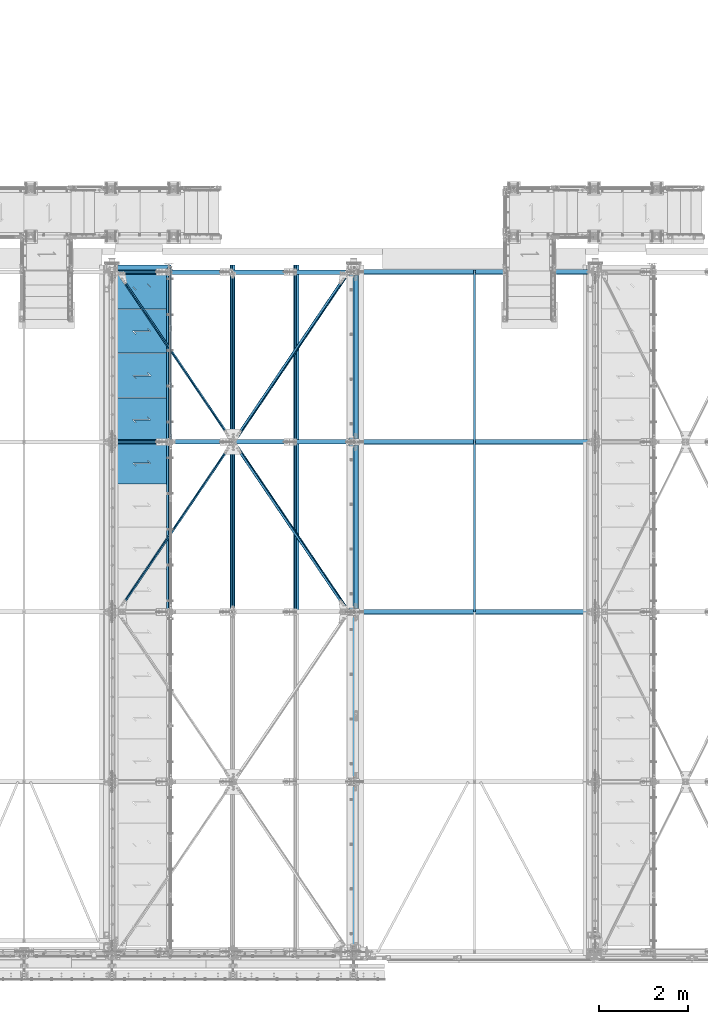
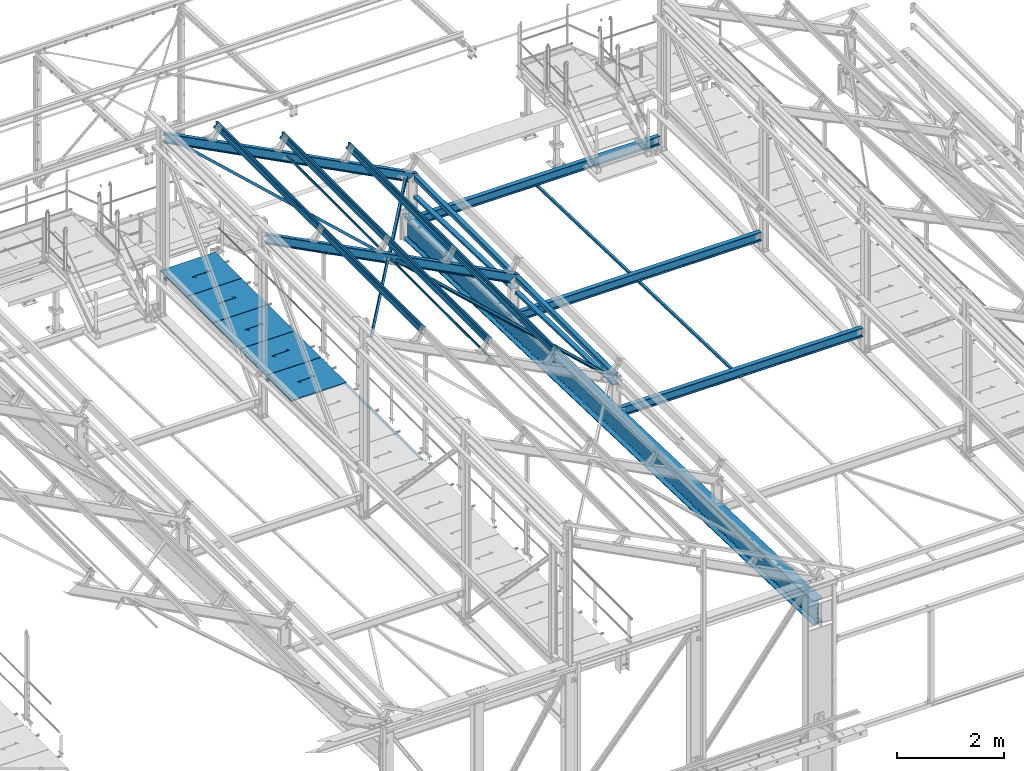
# One storey, part 51 of 496: 27 beams, 2 members, 29 elements without a shape of their own.
"""IFC2X3 building model written with IfcOpenShell, lengths in millimetres."""

from ifc_helpers import new_model, si_unit, frame, origin_with_axes, origin_2d_with_axis, place, context, subcontext, project, spatial, polyline, hollow_rectangle, hollow_circle, i_section, l_section, u_section, outline, extrude, boolean, clip, halfspace, material, type_object, element, aggregate, save


model = new_model("IFC2X3")

# Units and contexts
model_context = context("Model", 3, precision=1e-05, world=origin_with_axes())
body_context = subcontext(model_context, "Body", "Model", "MODEL_VIEW")
ifc_project = project(units=[si_unit("LENGTHUNIT", "METRE", prefix="MILLI"), si_unit("AREAUNIT", "SQUARE_METRE"), si_unit("VOLUMEUNIT", "CUBIC_METRE"), si_unit("MASSUNIT", "GRAM", prefix="KILO"), si_unit("TIMEUNIT", "SECOND"), si_unit("PLANEANGLEUNIT", "RADIAN"), si_unit("SOLIDANGLEUNIT", "STERADIAN"), si_unit("THERMODYNAMICTEMPERATUREUNIT", "DEGREE_CELSIUS"), si_unit("LUMINOUSINTENSITYUNIT", "LUMEN")], contexts=[model_context])

# Site, building, storey
site_placement = place(None, origin_with_axes())
site = spatial("IfcSite", under=ifc_project, at=site_placement, CompositionType="ELEMENT")
building_placement = place(site_placement, origin_with_axes())
building = spatial("IfcBuilding", under=site, at=building_placement, Name="Undefined", CompositionType="ELEMENT")
storey_placement = place(building_placement, origin_with_axes())
storey = spatial("IfcBuildingStorey", under=building, at=storey_placement, Name="Undefined", CompositionType="ELEMENT", Elevation=0.0)

# Assembly, beam
assembly_1_placement = place(storey_placement, origin_with_axes())
assembly_1 = element("IfcElementAssembly", 1, at=assembly_1_placement, inside=storey, AssemblyPlace="NOTDEFINED", PredefinedType="NOTDEFINED")
ifc_material_1 = material(Name="Undefined/S235-E24")
beam_type_1 = type_object("IfcBeamType", PredefinedType="NOTDEFINED")
beam_1_placement = place(assembly_1_placement, frame((31577.0000126664, 7601.07123853356, 7586.01904276004), z_axis=(1.0, 0.0, 0.0), x_axis=(0.0, 0.999506556345274, -0.0314108870109058)))
beam_1 = element("IfcBeam", 2, at=beam_1_placement, type_object=beam_type_1, material=ifc_material_1, context=body_context, shape_type="SweptSolid", body=[
    extrude(l_section(Depth=50.0, Width=50.0, Thickness=5.0, FilletRadius=7.0, EdgeRadius=3.5, at=origin_2d_with_axis()), frame((7648.75199419146, 0.0, 0.0), z_axis=(-1.0, 0.0, 0.0), x_axis=(0.0, -1.0, 0.0)), (0.0, 0.0, 1.0), 7648.75),
])
aggregate(assembly_1, [beam_1])

assembly_2_placement = place(storey_placement, origin_with_axes())
assembly_2 = element("IfcElementAssembly", 3, at=assembly_2_placement, inside=storey, Name="SUPPORT", AssemblyPlace="NOTDEFINED", PredefinedType="NOTDEFINED")
beam_2_placement = place(assembly_2_placement, frame((24711.4916006282, 15280.0000894508, 8074.99999999999), z_axis=(-1.0, 0.0, 0.0), x_axis=(0.0, -1.0, 0.0)))
beam_2 = element("IfcBeam", 4, at=beam_2_placement, type_object=beam_type_1, material=ifc_material_1, Name="SUPPORT", context=body_context, shape_type="SweptSolid", body=[
    extrude(l_section(Depth=50.0, Width=50.0, Thickness=5.0, FilletRadius=7.0, EdgeRadius=3.5, at=origin_2d_with_axis()), frame((7675.0000889974, 0.0, 0.0), z_axis=(-1.0, 0.0, 0.0), x_axis=(0.0, -1.0, 0.0)), (0.0, 0.0, 1.0), 7675.0),
])
aggregate(assembly_2, [beam_2])

assembly_3_placement = place(storey_placement, origin_with_axes())
assembly_3 = element("IfcElementAssembly", 5, at=assembly_3_placement, inside=storey, AssemblyPlace="NOTDEFINED", PredefinedType="NOTDEFINED")
beam_type_2 = type_object("IfcBeamType", PredefinedType="NOTDEFINED")
beam_3_placement = place(assembly_3_placement, frame((26190.921148286, 11401.8186771891, 9916.45624310865), z_axis=(0.460093364927087, 0.0, 0.887870539859315), x_axis=(0.538249849949882, -0.795292763925977, -0.278920272974034)))
beam_3 = element("IfcBeam", 6, at=beam_3_placement, type_object=beam_type_2, material=ifc_material_1, context=body_context, shape_type="Clipping", body=[
    clip(clip(extrude(l_section(Depth=60.0, Width=60.0, Thickness=6.0, FilletRadius=8.0, EdgeRadius=4.0, at=origin_2d_with_axis()), frame((4708.91827219578, 3.96472565002108e-12, 1.30698737171747e-13), z_axis=(-1.0, 0.0, 0.0), x_axis=(0.0, -1.0, 0.0)), (0.0, 0.0, 1.0), 4639.72), halfspace(frame((4626.03623708562, -29.992213240108, -29.9999759337006), z_axis=(-1.0, 0.0, 0.0), x_axis=(0.0, 1.0, 0.0)), True)), halfspace(frame((152.083672988732, -29.9999899169452, -29.9999991857003), z_axis=(1.0, 0.0, 0.0), x_axis=(0.0, 0.0, 1.0)), True)),
])
aggregate(assembly_3, [beam_3])

assembly_4_placement = place(storey_placement, origin_with_axes())
assembly_4 = element("IfcElementAssembly", 7, at=assembly_4_placement, inside=storey, AssemblyPlace="NOTDEFINED", PredefinedType="NOTDEFINED")
beam_4_placement = place(assembly_4_placement, frame((26190.9211477976, 11398.1813225519, 9916.45624339288), z_axis=(-0.706117074921334, 0.606225534605613, 0.365908837959236), x_axis=(0.538249829018613, 0.795292777027516, -0.278920276009645)))
beam_4 = element("IfcBeam", 8, at=beam_4_placement, type_object=beam_type_2, material=ifc_material_1, context=body_context, shape_type="Clipping", body=[
    clip(clip(extrude(l_section(Depth=60.0, Width=60.0, Thickness=6.0, FilletRadius=8.0, EdgeRadius=4.0, at=origin_2d_with_axis()), frame((4708.91859471881, 0.0, -1.88433877660764e-12), z_axis=(-1.0, 0.0, 0.0), x_axis=(0.0, -1.0, 0.0)), (0.0, 0.0, 1.0), 4639.72), halfspace(frame((4626.03655887688, 30.0000266849202, -30.0000000142745), z_axis=(1.0, 0.0, 0.0), x_axis=(0.0, -1.0, 0.0)), False)), halfspace(frame((152.084005931214, 30.0000008515817, -30.0000120938657), z_axis=(1.0, 0.0, 0.0), x_axis=(0.0, -1.0, 0.0)), True)),
])
aggregate(assembly_4, [beam_4])

assembly_5_placement = place(storey_placement, origin_with_axes())
assembly_5 = element("IfcElementAssembly", 9, at=assembly_5_placement, inside=storey, AssemblyPlace="NOTDEFINED", PredefinedType="NOTDEFINED")
beam_5_placement = place(assembly_5_placement, frame((23614.8650365102, 15198.1813229385, 11251.3647310532), z_axis=(0.706117071020689, 0.606225551793208, -0.36590881701072), x_axis=(0.538249849949882, -0.795292763925977, -0.278920272974034)))
beam_5 = element("IfcBeam", 10, at=beam_5_placement, type_object=beam_type_2, material=ifc_material_1, context=body_context, shape_type="Clipping", body=[
    clip(clip(extrude(l_section(Depth=60.0, Width=60.0, Thickness=6.0, FilletRadius=8.0, EdgeRadius=4.0, at=origin_2d_with_axis()), frame((4700.97227080409, 1.30478191329278e-13, 3.37702242443316e-12), z_axis=(-1.0, 0.0, 0.0), x_axis=(0.0, -1.0, 0.0)), (0.0, 0.0, 1.0), 4623.83), halfspace(frame((4626.03048038249, 29.9999980170396, -30.0000009319156), z_axis=(1.0, 0.0, 0.0), x_axis=(0.0, -1.0, 0.0)), False)), halfspace(frame((152.083880711965, 30.0000252853715, 30.0001237669021), z_axis=(1.0, 0.0, 0.0), x_axis=(0.0, 0.0, -1.0)), True)),
])
aggregate(assembly_5, [beam_5])

assembly_6_placement = place(storey_placement, origin_with_axes())
assembly_6 = element("IfcElementAssembly", 11, at=assembly_6_placement, inside=storey, AssemblyPlace="NOTDEFINED", PredefinedType="NOTDEFINED")
beam_6_placement = place(assembly_6_placement, frame((23614.8650363703, 7601.81867620068, 11251.3647310936), z_axis=(0.460093364927087, 0.0, 0.887870539859315), x_axis=(0.538249829018613, 0.795292777027516, -0.278920276009645)))
beam_6 = element("IfcBeam", 12, at=beam_6_placement, type_object=beam_type_2, material=ifc_material_1, context=body_context, shape_type="Clipping", body=[
    clip(clip(extrude(l_section(Depth=60.0, Width=60.0, Thickness=6.0, FilletRadius=8.0, EdgeRadius=4.0, at=origin_2d_with_axis()), frame((4700.97259588994, 1.95717300528334e-13, 2.60956400704445e-13), z_axis=(-1.0, 0.0, 0.0), x_axis=(0.0, -1.0, 0.0)), (0.0, 0.0, 1.0), 4623.83), halfspace(frame((4626.03080505285, -29.9999975810551, -30.0000004729009), z_axis=(1.0, 0.0, 0.0), x_axis=(0.0, 0.0, 1.0)), False)), halfspace(frame((152.084204340832, -30.0000009454561, -29.9999746402173), z_axis=(1.0, 0.0, 0.0), x_axis=(0.0, 0.0, 1.0)), True)),
])
aggregate(assembly_6, [beam_6])

assembly_7_placement = place(storey_placement, origin_with_axes())
assembly_7 = element("IfcElementAssembly", 13, at=assembly_7_placement, inside=storey, Name="LISSE", AssemblyPlace="NOTDEFINED", PredefinedType="NOTDEFINED")
beam_type_3 = type_object("IfcBeamType", PredefinedType="NOTDEFINED")
beam_7_placement = place(assembly_7_placement, frame((28930.0000000142, 11400.0, 8171.98873515491), z_axis=(1.0, 0.0, 0.0), x_axis=(0.0, 0.999506445341009, -0.0314144190107172)))
beam_7 = element("IfcBeam", 14, at=beam_7_placement, type_object=beam_type_3, material=ifc_material_1, Name="LISSE", context=body_context, shape_type="Clipping", body=[
    clip(clip(extrude(u_section(Depth=100.0, FlangeWidth=50.0, WebThickness=4.0, FlangeThickness=4.0, at=origin_2d_with_axis()), frame((3748.43634196934, 0.0, 0.0), z_axis=(-1.0, 0.0, 0.0), x_axis=(0.0, -1.0, 0.0)), (0.0, 0.0, 1.0), 3695.0), halfspace(frame((3745.45325324851, 44.4149471719229, 54.9999999858046), z_axis=(-0.999506472307554, -0.0314135610096736, 0.0), x_axis=(0.0, 0.0, 1.0)), True)), halfspace(frame((53.9730354263374, 33.5397111128605, 54.9999999858046), z_axis=(-0.999506472307554, -0.0314135610096736, 0.0), x_axis=(0.0, 0.0, 1.0)), False)),
])
aggregate(assembly_7, [beam_7])

assembly_8_placement = place(storey_placement, origin_with_axes())
assembly_8 = element("IfcElementAssembly", 15, at=assembly_8_placement, inside=storey, Name="LISSE", AssemblyPlace="NOTDEFINED", PredefinedType="NOTDEFINED")
beam_8_placement = place(assembly_8_placement, frame((28930.0000000087, 7600.0, 8291.42237510326), z_axis=(1.0, 0.0, 0.0), x_axis=(0.0, 0.999506445341009, -0.0314144190107172)))
beam_8 = element("IfcBeam", 16, at=beam_8_placement, type_object=beam_type_3, material=ifc_material_1, Name="LISSE", context=body_context, shape_type="Clipping", body=[
    clip(clip(extrude(u_section(Depth=100.0, FlangeWidth=50.0, WebThickness=4.0, FlangeThickness=4.0, at=origin_2d_with_axis()), frame((3748.43648207257, 2.60100030546368e-14, 0.0), z_axis=(-1.0, 0.0, 0.0), x_axis=(0.0, -1.0, 0.0)), (0.0, 0.0, 1.0), 3695.0), halfspace(frame((3745.62054377058, 39.0942342224898, 54.9999999913198), z_axis=(-0.999506472307554, -0.0314135610096736, 0.0), x_axis=(0.0, 0.0, 1.0)), True)), halfspace(frame((53.9255505764258, 35.049685220647, 54.9999999913198), z_axis=(-0.999506472307554, -0.0314135610096736, 0.0), x_axis=(0.0, 0.0, 1.0)), False)),
])
aggregate(assembly_8, [beam_8])

assembly_9_placement = place(storey_placement, origin_with_axes())
assembly_9 = element("IfcElementAssembly", 17, at=assembly_9_placement, inside=storey, Name="LISSE", AssemblyPlace="NOTDEFINED", PredefinedType="NOTDEFINED")
beam_type_4 = type_object("IfcBeamType", PredefinedType="NOTDEFINED")
beam_9_placement = place(assembly_9_placement, frame((28929.9999999877, 11470.0, 8500.0), z_axis=(0.0, 0.0, 1.0), x_axis=(0.0, 1.0, 0.0)))
beam_9 = element("IfcBeam", 18, at=beam_9_placement, type_object=beam_type_4, material=ifc_material_1, Name="LISSE", context=body_context, shape_type="SweptSolid", body=[
    extrude(hollow_rectangle(XDim=100.0, YDim=100.0, WallThickness=4.0, InnerFilletRadius=4.0, OuterFilletRadius=8.0, at=origin_2d_with_axis()), frame((3660.0, 0.0, 0.0), z_axis=(-1.0, 0.0, 0.0), x_axis=(0.0, -1.0, 0.0)), (0.0, 0.0, 1.0), 3660.0),
])
aggregate(assembly_9, [beam_9])

assembly_10_placement = place(storey_placement, origin_with_axes())
assembly_10 = element("IfcElementAssembly", 19, at=assembly_10_placement, inside=storey, Name="LISSE", AssemblyPlace="NOTDEFINED", PredefinedType="NOTDEFINED")
beam_10_placement = place(assembly_10_placement, frame((28929.9999999877, 7670.0, 8500.0), z_axis=(0.0, 0.0, 1.0), x_axis=(0.0, 1.0, 0.0)))
beam_10 = element("IfcBeam", 20, at=beam_10_placement, type_object=beam_type_4, material=ifc_material_1, Name="LISSE", context=body_context, shape_type="SweptSolid", body=[
    extrude(hollow_rectangle(XDim=100.0, YDim=100.0, WallThickness=4.0, InnerFilletRadius=4.0, OuterFilletRadius=8.0, at=origin_2d_with_axis()), frame((3660.0, 0.0, 0.0), z_axis=(-1.0, 0.0, 0.0), x_axis=(0.0, -1.0, 0.0)), (0.0, 0.0, 1.0), 3660.0),
])
aggregate(assembly_10, [beam_10])

assembly_11_placement = place(storey_placement, origin_with_axes())
assembly_11 = element("IfcElementAssembly", 21, at=assembly_11_placement, inside=storey, AssemblyPlace="NOTDEFINED", PredefinedType="NOTDEFINED")
beam_type_5 = type_object("IfcBeamType", PredefinedType="NOTDEFINED")
beam_11_placement = place(assembly_11_placement, frame((24726.4915934611, 15355.0001427662, 8115.0), z_axis=(0.0, 0.0, 1.0), x_axis=(-1.0, 0.0, 0.0)))
beam_11 = element("IfcBeam", 22, at=beam_11_placement, type_object=beam_type_5, material=ifc_material_1, context=body_context, shape_type="CSG", body=[
    boolean("DIFFERENCE", extrude(outline(polyline([(0.0, 0.0), (1179.99169921875, 0.0), (1179.99169921875, 980.0), (-9.39995516091585e-07, 980.0), (0.0, 0.0)])), frame((0.0, 0.0, -15.0), z_axis=(0.0, 0.0, 1.0), x_axis=(1.0, 0.0, 0.0)), (0.0, 0.0, 1.0), 30.0), extrude(outline(polyline([(0.0, 0.0), (9.99999999997453, 6.91215973347425e-11), (10.0000000004329, 75.8578643791443), (282.842712400121, -196.984848017997), (282.842712400743, -96.9848480190813), (272.842712400776, -96.9848480191613), (272.842712400299, -172.842712398218), (0.0, 100.0), (0.0, 0.0)])), frame((724.286946489367, 555.710676888644, -17.5), z_axis=(0.0, 0.0, 1.0), x_axis=(-0.707106781186457, -0.707106781186639, 0.0)), (0.0, 0.0, 1.0), 35.0)),
])
aggregate(assembly_11, [beam_11])

assembly_12_placement = place(storey_placement, origin_with_axes())
assembly_12 = element("IfcElementAssembly", 23, at=assembly_12_placement, inside=storey, AssemblyPlace="NOTDEFINED", PredefinedType="NOTDEFINED")
beam_12_placement = place(assembly_12_placement, frame((24726.4915934611, 14365.0001475355, 8115.0), z_axis=(0.0, 0.0, 1.0), x_axis=(-1.0, 0.0, 0.0)))
beam_12 = element("IfcBeam", 24, at=beam_12_placement, type_object=beam_type_5, material=ifc_material_1, context=body_context, shape_type="CSG", body=[
    boolean("DIFFERENCE", extrude(outline(polyline([(0.0, 0.0), (1179.99169921875, 0.0), (1179.99169921875, 980.0), (-9.39995516091585e-07, 980.0), (0.0, 0.0)])), frame((0.0, 0.0, -15.0), z_axis=(0.0, 0.0, 1.0), x_axis=(1.0, 0.0, 0.0)), (0.0, 0.0, 1.0), 30.0), extrude(outline(polyline([(0.0, 0.0), (9.99999999997453, 6.91215973347425e-11), (10.0000000004329, 75.8578643791443), (282.842712400121, -196.984848017997), (282.842712400743, -96.9848480190813), (272.842712400776, -96.9848480191613), (272.842712400299, -172.842712398218), (0.0, 100.0), (0.0, 0.0)])), frame((724.286946489367, 555.710676888644, -17.5), z_axis=(0.0, 0.0, 1.0), x_axis=(-0.707106781186457, -0.707106781186639, 0.0)), (0.0, 0.0, 1.0), 35.0)),
])
aggregate(assembly_12, [beam_12])

assembly_13_placement = place(storey_placement, origin_with_axes())
assembly_13 = element("IfcElementAssembly", 25, at=assembly_13_placement, inside=storey, AssemblyPlace="NOTDEFINED", PredefinedType="NOTDEFINED")
beam_13_placement = place(assembly_13_placement, frame((24726.4915934611, 13375.0001523048, 8115.0), z_axis=(0.0, 0.0, 1.0), x_axis=(-1.0, 0.0, 0.0)))
beam_13 = element("IfcBeam", 26, at=beam_13_placement, type_object=beam_type_5, material=ifc_material_1, context=body_context, shape_type="CSG", body=[
    boolean("DIFFERENCE", extrude(outline(polyline([(0.0, 0.0), (1179.99169921875, 0.0), (1179.99169921875, 980.0), (-9.39995516091585e-07, 980.0), (0.0, 0.0)])), frame((0.0, 0.0, -15.0), z_axis=(0.0, 0.0, 1.0), x_axis=(1.0, 0.0, 0.0)), (0.0, 0.0, 1.0), 30.0), extrude(outline(polyline([(0.0, 0.0), (9.99999999997453, 6.91215973347425e-11), (10.0000000004329, 75.8578643791443), (282.842712400121, -196.984848017997), (282.842712400743, -96.9848480190813), (272.842712400776, -96.9848480191613), (272.842712400299, -172.842712398218), (0.0, 100.0), (0.0, 0.0)])), frame((724.286946489367, 555.710676888644, -17.5), z_axis=(0.0, 0.0, 1.0), x_axis=(-0.707106781186457, -0.707106781186639, 0.0)), (0.0, 0.0, 1.0), 35.0)),
])
aggregate(assembly_13, [beam_13])

assembly_14_placement = place(storey_placement, origin_with_axes())
assembly_14 = element("IfcElementAssembly", 27, at=assembly_14_placement, inside=storey, AssemblyPlace="NOTDEFINED", PredefinedType="NOTDEFINED")
beam_14_placement = place(assembly_14_placement, frame((24726.4915934611, 12385.000157074, 8115.0), z_axis=(0.0, 0.0, 1.0), x_axis=(-1.0, 0.0, 0.0)))
beam_14 = element("IfcBeam", 28, at=beam_14_placement, type_object=beam_type_5, material=ifc_material_1, context=body_context, shape_type="CSG", body=[
    boolean("DIFFERENCE", extrude(outline(polyline([(0.0, 0.0), (1179.99169921875, 0.0), (1179.99169921875, 980.0), (-9.39995516091585e-07, 980.0), (0.0, 0.0)])), frame((0.0, 0.0, -15.0), z_axis=(0.0, 0.0, 1.0), x_axis=(1.0, 0.0, 0.0)), (0.0, 0.0, 1.0), 30.0), extrude(outline(polyline([(0.0, 0.0), (9.99999999997453, 6.91215973347425e-11), (10.0000000004329, 75.8578643791443), (282.842712400121, -196.984848017997), (282.842712400743, -96.9848480190813), (272.842712400776, -96.9848480191613), (272.842712400299, -172.842712398218), (0.0, 100.0), (0.0, 0.0)])), frame((724.286946489367, 555.710676888644, -17.5), z_axis=(0.0, 0.0, 1.0), x_axis=(-0.707106781186457, -0.707106781186639, 0.0)), (0.0, 0.0, 1.0), 35.0)),
])
aggregate(assembly_14, [beam_14])

assembly_15_placement = place(storey_placement, origin_with_axes())
assembly_15 = element("IfcElementAssembly", 29, at=assembly_15_placement, inside=storey, AssemblyPlace="NOTDEFINED", PredefinedType="NOTDEFINED")
beam_type_6 = type_object("IfcBeamType", PredefinedType="NOTDEFINED")
beam_15_placement = place(assembly_15_placement, frame((24726.4916105611, 11395.0001618433, 8115.0), z_axis=(0.0, 0.0, 1.0), x_axis=(-1.0, 0.0, 0.0)))
beam_15 = element("IfcBeam", 30, at=beam_15_placement, type_object=beam_type_6, material=ifc_material_1, context=body_context, shape_type="CSG", body=[
    boolean("DIFFERENCE", extrude(outline(polyline([(0.0, 0.0), (1179.99169921875, 0.0), (1179.99169921875, 940.0), (-9.39995516091585e-07, 940.0), (0.0, 0.0)])), frame((0.0, 0.0, -15.0), z_axis=(0.0, 0.0, 1.0), x_axis=(1.0, 0.0, 0.0)), (0.0, 0.0, 1.0), 30.0), extrude(outline(polyline([(0.0, 0.0), (9.99999999997453, 6.91215973347425e-11), (10.0000000004329, 75.8578643791443), (282.842712400121, -196.984848017997), (282.842712400743, -96.9848480190813), (272.842712400776, -96.9848480191613), (272.842712400299, -172.842712398218), (0.0, 100.0), (0.0, 0.0)])), frame((724.286946489367, 535.710676888644, -17.5), z_axis=(0.0, 0.0, 1.0), x_axis=(-0.707106781186457, -0.707106781186639, 0.0)), (0.0, 0.0, 1.0), 35.0)),
])
aggregate(assembly_15, [beam_15])

assembly_16_placement = place(storey_placement, origin_with_axes())
assembly_16 = element("IfcElementAssembly", 31, at=assembly_16_placement, inside=storey, Name="MAIN COURANTE", AssemblyPlace="NOTDEFINED", PredefinedType="NOTDEFINED")
beam_type_7 = type_object("IfcBeamType", PredefinedType="NOTDEFINED")
beam_16_placement = place(assembly_16_placement, frame((24783.9916088665, 15300.003440146, 8673.7999966088), z_axis=(0.0, 0.0, 1.0), x_axis=(0.0, -1.0, 0.0)))
beam_16 = element("IfcBeam", 32, at=beam_16_placement, type_object=beam_type_7, material=ifc_material_1, Name="LISSE", context=body_context, shape_type="SweptSolid", body=[
    extrude(hollow_circle(Radius=13.44999981, WallThickness=2.0, at=origin_2d_with_axis()), frame((3845.0034383235, -7.91283071904719e-22, 7.95128074845232e-22), z_axis=(-1.0, 0.0, 0.0), x_axis=(0.0, -1.0, 0.0)), (0.0, 0.0, 1.0), 3845.0),
])
aggregate(assembly_16, [beam_16])

assembly_17_placement = place(storey_placement, origin_with_axes())
assembly_17 = element("IfcElementAssembly", 33, at=assembly_17_placement, inside=storey, AssemblyPlace="NOTDEFINED", PredefinedType="NOTDEFINED")
beam_type_8 = type_object("IfcBeamType", PredefinedType="NOTDEFINED")
beam_17_placement = place(assembly_17_placement, frame((26184.2061440592, 11320.001746698, 9908.67304663742), z_axis=(-0.887870604061621, -1.29999898490562e-08, 0.460093241031915), x_axis=(0.0, -1.0, 0.0)))
beam_17 = element("IfcBeam", 34, at=beam_17_placement, type_object=beam_type_8, material=ifc_material_1, context=body_context, shape_type="SweptSolid", body=[
    extrude(hollow_rectangle(XDim=40.0, YDim=40.0, WallThickness=4.0, InnerFilletRadius=4.0, OuterFilletRadius=8.0, at=origin_2d_with_axis()), frame((3700.00159576542, -3.63797880709171e-12, -3.63797880709171e-12), z_axis=(-1.0, 0.0, 0.0), x_axis=(0.0, -1.0, 0.0)), (0.0, 0.0, 1.0), 3700.0),
])
aggregate(assembly_17, [beam_17])

assembly_18_placement = place(storey_placement, origin_with_axes())
assembly_18 = element("IfcElementAssembly", 35, at=assembly_18_placement, inside=storey, AssemblyPlace="NOTDEFINED", PredefinedType="NOTDEFINED")
beam_18_placement = place(assembly_18_placement, frame((26184.2061471172, 15180.0001509325, 9908.67304481363), z_axis=(-0.887870604061621, -1.29999898490562e-08, 0.460093241031915), x_axis=(-8.13000000285402e-07, -0.999999999999581, 4.20999999948846e-07)))
beam_18 = element("IfcBeam", 36, at=beam_18_placement, type_object=beam_type_8, material=ifc_material_1, context=body_context, shape_type="SweptSolid", body=[
    extrude(hollow_rectangle(XDim=40.0, YDim=40.0, WallThickness=4.0, InnerFilletRadius=4.0, OuterFilletRadius=8.0, at=origin_2d_with_axis()), frame((3700.00150276796, -3.63797900296816e-12, -3.9175289721686e-19), z_axis=(-1.0, 0.0, 0.0), x_axis=(0.0, -1.0, 0.0)), (0.0, 0.0, 1.0), 3700.0),
])
aggregate(assembly_18, [beam_18])

assembly_19_placement = place(storey_placement, origin_with_axes())
assembly_19 = element("IfcElementAssembly", 37, at=assembly_19_placement, inside=storey, Name="SHED", AssemblyPlace="NOTDEFINED", PredefinedType="NOTDEFINED")
beam_type_9 = type_object("IfcBeamType", PredefinedType="NOTDEFINED")
beam_19_placement = place(assembly_19_placement, frame((27591.6811455118, 7605.00007961586, 9562.26025626068), z_axis=(0.460093364927087, 0.0, 0.887870539859315), x_axis=(0.0, 1.0, 0.0)))
beam_19 = element("IfcBeam", 38, at=beam_19_placement, type_object=beam_type_9, material=ifc_material_1, Name="SHED", context=body_context, shape_type="SweptSolid", body=[
    extrude(outline(polyline([(-27.9999999860338, 36.0000000101354), (-27.999999986052, 70.0000000101354), (28.0000000138389, 70.0000000101209), (28.0000000138425, 58.0000000101209), (26.5000000138534, 58.0000000101209), (26.5000000138352, 68.5000000101172), (-26.4999999860593, 68.5000000101354), (-26.4999999860338, 36.7000007730749), (-1.49999998607018, 15.6999998194005), (-1.49999998605563, -15.6999997991297), (-26.4999999859974, -36.7000007527895), (-26.4999999859829, -68.49999998985), (26.5000000139153, -68.4999999898646), (26.500000013908, -57.9999999898646), (28.0000000139116, -57.9999999898646), (28.0000000139153, -69.9999999898646), (-27.9999999859756, -69.99999998985), (-27.9999999859901, -35.99999998985), (-2.99999998605927, -14.9999999898646), (-2.9999999860629, 15.0000000101354), (-27.9999999860338, 36.0000000101354)])), frame((7750.00000000006, -3.63797880548905e-12, 0.0), z_axis=(-1.0, 0.0, 0.0), x_axis=(0.0, -1.0, 0.0)), (0.0, 0.0, 1.0), 7750.0),
])
aggregate(assembly_19, [beam_19])

assembly_20_placement = place(storey_placement, origin_with_axes())
assembly_20 = element("IfcElementAssembly", 39, at=assembly_20_placement, inside=storey, Name="SHED", AssemblyPlace="NOTDEFINED", PredefinedType="NOTDEFINED")
beam_20_placement = place(assembly_20_placement, frame((26165.0561444964, 7605.00007961586, 10301.5352325358), z_axis=(0.460093364927087, 0.0, 0.887870539859315), x_axis=(0.0, 1.0, 0.0)))
beam_20 = element("IfcBeam", 40, at=beam_20_placement, type_object=beam_type_9, material=ifc_material_1, Name="SHED", context=body_context, shape_type="SweptSolid", body=[
    extrude(outline(polyline([(-27.9999999860338, 36.0000000101354), (-27.999999986052, 70.0000000101354), (28.0000000138389, 70.0000000101209), (28.0000000138425, 58.0000000101209), (26.5000000138534, 58.0000000101209), (26.5000000138352, 68.5000000101172), (-26.4999999860593, 68.5000000101354), (-26.4999999860338, 36.7000007730749), (-1.49999998607018, 15.6999998194005), (-1.49999998605563, -15.6999997991297), (-26.4999999859974, -36.7000007527895), (-26.4999999859829, -68.49999998985), (26.5000000139153, -68.4999999898646), (26.500000013908, -57.9999999898646), (28.0000000139116, -57.9999999898646), (28.0000000139153, -69.9999999898646), (-27.9999999859756, -69.99999998985), (-27.9999999859901, -35.99999998985), (-2.99999998605927, -14.9999999898646), (-2.9999999860629, 15.0000000101354), (-27.9999999860338, 36.0000000101354)])), frame((7750.00000000006, -3.63797880548905e-12, 0.0), z_axis=(-1.0, 0.0, 0.0), x_axis=(0.0, -1.0, 0.0)), (0.0, 0.0, 1.0), 7750.0),
])
aggregate(assembly_20, [beam_20])

assembly_21_placement = place(storey_placement, origin_with_axes())
assembly_21 = element("IfcElementAssembly", 41, at=assembly_21_placement, inside=storey, Name="SHED", AssemblyPlace="NOTDEFINED", PredefinedType="NOTDEFINED")
beam_21_placement = place(assembly_21_placement, frame((24738.431143481, 7605.00007961586, 11040.8102088141), z_axis=(0.460093364927087, 0.0, 0.887870539859315), x_axis=(0.0, 1.0, 0.0)))
beam_21 = element("IfcBeam", 42, at=beam_21_placement, type_object=beam_type_9, material=ifc_material_1, Name="SHED", context=body_context, shape_type="SweptSolid", body=[
    extrude(outline(polyline([(-27.9999999860338, 36.0000000101354), (-27.999999986052, 70.0000000101354), (28.0000000138389, 70.0000000101209), (28.0000000138425, 58.0000000101209), (26.5000000138534, 58.0000000101209), (26.5000000138352, 68.5000000101172), (-26.4999999860593, 68.5000000101354), (-26.4999999860338, 36.7000007730749), (-1.49999998607018, 15.6999998194005), (-1.49999998605563, -15.6999997991297), (-26.4999999859974, -36.7000007527895), (-26.4999999859829, -68.49999998985), (26.5000000139153, -68.4999999898646), (26.500000013908, -57.9999999898646), (28.0000000139116, -57.9999999898646), (28.0000000139153, -69.9999999898646), (-27.9999999859756, -69.99999998985), (-27.9999999859901, -35.99999998985), (-2.99999998605927, -14.9999999898646), (-2.9999999860629, 15.0000000101354), (-27.9999999860338, 36.0000000101354)])), frame((7750.00000000006, -3.63797880548905e-12, 0.0), z_axis=(-1.0, 0.0, 0.0), x_axis=(0.0, -1.0, 0.0)), (0.0, 0.0, 1.0), 7750.0),
])
aggregate(assembly_21, [beam_21])

assembly_22_placement = place(storey_placement, origin_with_axes())
assembly_22 = element("IfcElementAssembly", 43, at=assembly_22_placement, inside=storey, AssemblyPlace="NOTDEFINED", PredefinedType="NOTDEFINED")
beam_type_10 = type_object("IfcBeamType", PredefinedType="NOTDEFINED")
beam_22_placement = place(assembly_22_placement, frame((23547.9918295866, 15200.0, 8015.0), z_axis=(0.0, -1.0, 0.0), x_axis=(1.0, 0.0, 0.0)))
beam_22 = element("IfcBeam", 44, at=beam_22_placement, type_object=beam_type_10, material=ifc_material_1, context=body_context, shape_type="SweptSolid", body=[
    extrude(hollow_rectangle(XDim=60.0, YDim=60.0, WallThickness=3.0, InnerFilletRadius=3.0, OuterFilletRadius=6.0, at=origin_2d_with_axis()), frame((1181.99977105896, 0.0, 0.0), z_axis=(-1.0, 0.0, 0.0), x_axis=(0.0, -1.0, 0.0)), (0.0, 0.0, 1.0), 1182.0),
])
aggregate(assembly_22, [beam_22])

assembly_23_placement = place(storey_placement, origin_with_axes())
assembly_23 = element("IfcElementAssembly", 45, at=assembly_23_placement, inside=storey, AssemblyPlace="NOTDEFINED", PredefinedType="NOTDEFINED")
beam_23_placement = place(assembly_23_placement, frame((23547.9918295866, 11400.0, 8015.0), z_axis=(0.0, -1.0, 0.0), x_axis=(1.0, 0.0, 0.0)))
beam_23 = element("IfcBeam", 46, at=beam_23_placement, type_object=beam_type_10, material=ifc_material_1, context=body_context, shape_type="SweptSolid", body=[
    extrude(hollow_rectangle(XDim=60.0, YDim=60.0, WallThickness=3.0, InnerFilletRadius=3.0, OuterFilletRadius=6.0, at=origin_2d_with_axis()), frame((1181.99977105896, 0.0, 0.0), z_axis=(-1.0, 0.0, 0.0), x_axis=(0.0, -1.0, 0.0)), (0.0, 0.0, 1.0), 1182.0),
])
aggregate(assembly_23, [beam_23])

# Assembly, member
assembly_24_placement = place(storey_placement, origin_with_axes())
assembly_24 = element("IfcElementAssembly", 47, at=assembly_24_placement, inside=storey, Name="TRAVERSE SHED", AssemblyPlace="NOTDEFINED", PredefinedType="NOTDEFINED")
ifc_material_2 = material(Name="Undefined/S275-E28")
member_type = type_object("IfcMemberType", Name="IPE200", PredefinedType="NOTDEFINED")
member_1_placement = place(assembly_24_placement, frame((23493.9906758698, 15199.9999999968, 11280.2129396085), z_axis=(0.460093364927087, 0.0, 0.887870539859315), x_axis=(0.887870604061616, 0.0, -0.460093241031926)))
member_1 = element("IfcMember", 48, at=member_1_placement, type_object=member_type, material=ifc_material_2, Name="TRAVERSE SHED", ObjectType="IPE200", context=body_context, shape_type="Clipping", body=[
    clip(clip(extrude(i_section(OverallWidth=100.0, OverallDepth=200.0, WebThickness=5.599999905, FlangeThickness=8.5, FilletRadius=12.0, at=origin_2d_with_axis()), frame((6236.48041099405, -1.81898940354586e-12, 0.0), z_axis=(-1.0, 0.0, 0.0), x_axis=(0.0, -1.0, 0.0)), (0.0, 0.0, 1.0), 6347.61), halfspace(frame((6005.40058860125, -11399.9999999968, -99.9999999999964), z_axis=(0.854427655127558, 0.0, -0.519570382290236), x_axis=(0.0, -1.0, 0.0)), False)), halfspace(frame((5.77115893586233, 3.18409305520223e-09, 102.990606066072), z_axis=(-0.887870604061619, 0.0, -0.46009324103192), x_axis=(0.0, -1.0, 0.0)), False)),
])
aggregate(assembly_24, [member_1])

assembly_25_placement = place(storey_placement, origin_with_axes())
assembly_25 = element("IfcElementAssembly", 49, at=assembly_25_placement, inside=storey, Name="TRAVERSE SHED", AssemblyPlace="NOTDEFINED", PredefinedType="NOTDEFINED")
member_2_placement = place(assembly_25_placement, frame((23493.9906758698, 11399.9999999968, 11280.2129396085), z_axis=(0.460093364927087, 0.0, 0.887870539859315), x_axis=(0.887870604061616, 0.0, -0.460093241031926)))
member_2 = element("IfcMember", 50, at=member_2_placement, type_object=member_type, material=ifc_material_2, Name="TRAVERSE SHED", ObjectType="IPE200", context=body_context, shape_type="Clipping", body=[
    clip(clip(extrude(i_section(OverallWidth=100.0, OverallDepth=200.0, WebThickness=5.599999905, FlangeThickness=8.5, FilletRadius=12.0, at=origin_2d_with_axis()), frame((6236.48041099405, -1.81898940354586e-12, 0.0), z_axis=(-1.0, 0.0, 0.0), x_axis=(0.0, -1.0, 0.0)), (0.0, 0.0, 1.0), 6347.61), halfspace(frame((6005.40058860125, -7599.99999999682, -99.9999999999964), z_axis=(0.854427655127558, 0.0, -0.519570382290236), x_axis=(0.0, -1.0, 0.0)), False)), halfspace(frame((5.77115893586233, 3.18409305520223e-09, 102.990606066072), z_axis=(-0.887870604061619, 0.0, -0.46009324103192), x_axis=(0.0, -1.0, 0.0)), False)),
])
aggregate(assembly_25, [member_2])

# Assembly, beam
assembly_26_placement = place(storey_placement, origin_with_axes())
assembly_26 = element("IfcElementAssembly", 51, at=assembly_26_placement, inside=storey, AssemblyPlace="NOTDEFINED", PredefinedType="NOTDEFINED")
beam_type_11 = type_object("IfcBeamType", Name="IPE200", PredefinedType="NOTDEFINED")
beam_24_placement = place(assembly_26_placement, frame((28989.9999991865, 15199.9999999708, 7472.2713136278), z_axis=(0.0, 0.031410887010906, 0.999506556345274), x_axis=(1.0, 0.0, 0.0)))
beam_24 = element("IfcBeam", 52, at=beam_24_placement, type_object=beam_type_11, material=ifc_material_2, ObjectType="IPE200", context=body_context, shape_type="SweptSolid", body=[
    extrude(i_section(OverallWidth=100.0, OverallDepth=200.0, WebThickness=5.599999905, FlangeThickness=8.5, FilletRadius=12.0, at=origin_2d_with_axis()), frame((5213.49999999568, 0.0, 0.0), z_axis=(-1.0, 0.0, 0.0), x_axis=(0.0, -1.0, 0.0)), (0.0, 0.0, 1.0), 5213.5),
])
aggregate(assembly_26, [beam_24])

assembly_27_placement = place(storey_placement, origin_with_axes())
assembly_27 = element("IfcElementAssembly", 53, at=assembly_27_placement, inside=storey, AssemblyPlace="NOTDEFINED", PredefinedType="NOTDEFINED")
beam_25_placement = place(assembly_27_placement, frame((28989.9999999984, 11399.9999999766, 7591.69161146022), z_axis=(0.0, 0.031410887010906, 0.999506556345274), x_axis=(1.0, 0.0, 0.0)))
beam_25 = element("IfcBeam", 54, at=beam_25_placement, type_object=beam_type_11, material=ifc_material_2, ObjectType="IPE200", context=body_context, shape_type="SweptSolid", body=[
    extrude(i_section(OverallWidth=100.0, OverallDepth=200.0, WebThickness=5.599999905, FlangeThickness=8.5, FilletRadius=12.0, at=origin_2d_with_axis()), frame((5213.49999999568, 0.0, 0.0), z_axis=(-1.0, 0.0, 0.0), x_axis=(0.0, -1.0, 0.0)), (0.0, 0.0, 1.0), 5213.5),
])
aggregate(assembly_27, [beam_25])

assembly_28_placement = place(storey_placement, origin_with_axes())
assembly_28 = element("IfcElementAssembly", 55, at=assembly_28_placement, inside=storey, AssemblyPlace="NOTDEFINED", PredefinedType="NOTDEFINED")
beam_26_placement = place(assembly_28_placement, frame((28989.9999999989, 7599.99999998237, 7711.11190929265), z_axis=(0.0, 0.031410887010906, 0.999506556345274), x_axis=(1.0, 0.0, 0.0)))
beam_26 = element("IfcBeam", 56, at=beam_26_placement, type_object=beam_type_11, material=ifc_material_2, ObjectType="IPE200", context=body_context, shape_type="SweptSolid", body=[
    extrude(i_section(OverallWidth=100.0, OverallDepth=200.0, WebThickness=5.599999905, FlangeThickness=8.5, FilletRadius=12.0, at=origin_2d_with_axis()), frame((5213.49999999568, 0.0, 0.0), z_axis=(-1.0, 0.0, 0.0), x_axis=(0.0, -1.0, 0.0)), (0.0, 0.0, 1.0), 5213.5),
])
aggregate(assembly_28, [beam_26])

assembly_29_placement = place(storey_placement, origin_with_axes())
assembly_29 = element("IfcElementAssembly", 57, at=assembly_29_placement, inside=storey, Name="TRAVERSE", AssemblyPlace="NOTDEFINED", PredefinedType="NOTDEFINED")
beam_type_12 = type_object("IfcBeamType", Name="IPE550", PredefinedType="NOTDEFINED")
beam_27_placement = place(assembly_29_placement, frame((28880.0000000007, -8.63795872800654, 7775.13569589744), z_axis=(0.0, -0.031410887010906, -0.999506556345274), x_axis=(0.0, 0.999506556345274, -0.0314108870109058)))
beam_27 = element("IfcBeam", 58, at=beam_27_placement, type_object=beam_type_12, material=ifc_material_2, Name="TRAVERSE", ObjectType="IPE550", context=body_context, shape_type="Clipping", body=[
    clip(clip(extrude(i_section(OverallWidth=210.0, OverallDepth=550.0, WebThickness=11.10000038, FlangeThickness=17.20000076, FilletRadius=24.0, at=origin_2d_with_axis()), frame((15397.5977849943, 0.0, 0.0), z_axis=(-1.0, 0.0, 0.0), x_axis=(0.0, -1.0, 0.0)), (0.0, 0.0, 1.0), 15385.4), halfspace(frame((15357.5780376579, -105.0, -275.0), z_axis=(0.999506560367824, 0.0, -0.0314107590115582), x_axis=(0.0314107590115582, 0.0, 0.999506560367824)), False)), halfspace(frame((21.2106227916131, -7.13043846189976e-10, -268.62776844064), z_axis=(-0.999506560367824, 0.0, 0.0314107590115593), x_axis=(0.0, 1.0, 0.0)), False)),
])
aggregate(assembly_29, [beam_27])

save(model, "model.ifc")
